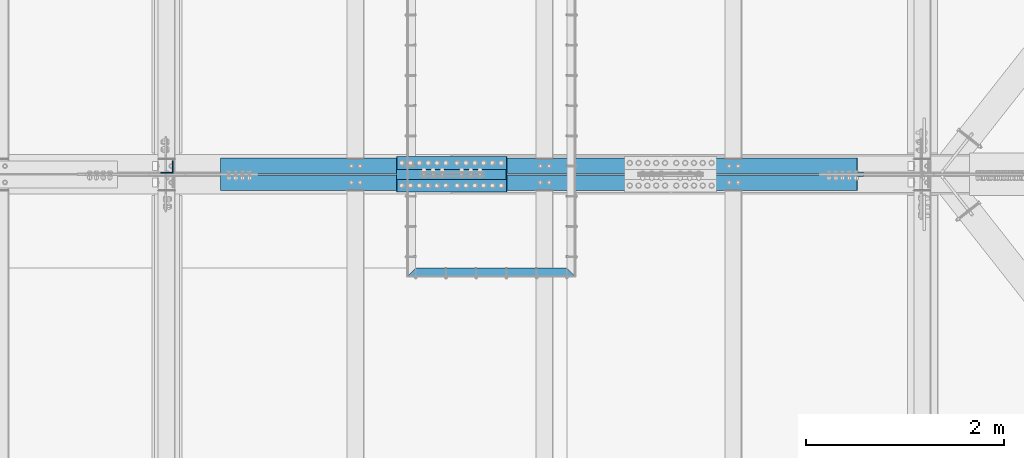
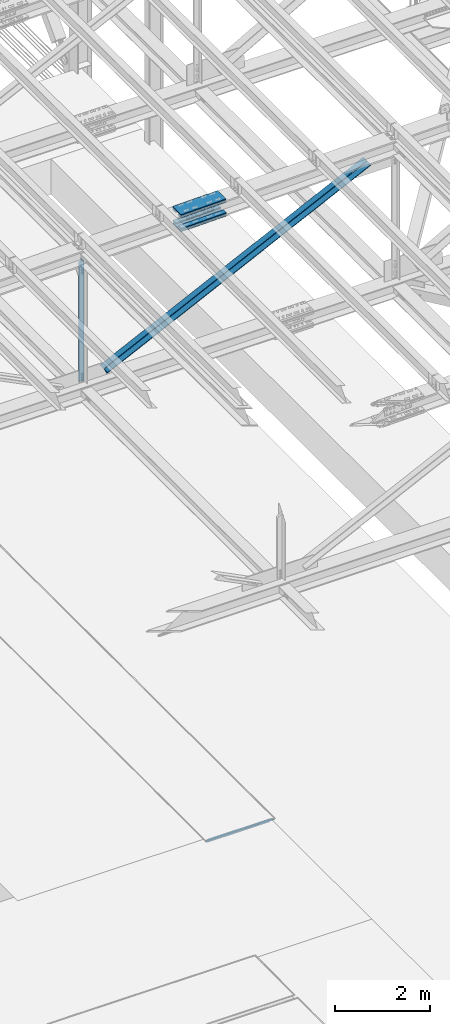
# One storey, part 1898 of 3843: 8 beams, 2 members, 5 elements without a shape of their own.
"""IFC2X3 building model written with IfcOpenShell, lengths in millimetres."""

from ifc_helpers import new_model, si_unit, frame, origin_with_axes, place, context, subcontext, project, spatial, faceted_brep, material, type_object, element, aggregate, save


model = new_model("IFC2X3")

# Units and contexts
model_context = context("Model", 3, precision=1e-05, world=origin_with_axes())
body_context = subcontext(model_context, "Body", "Model", "MODEL_VIEW")
ifc_project = project(units=[si_unit("LENGTHUNIT", "METRE", prefix="MILLI"), si_unit("AREAUNIT", "SQUARE_METRE"), si_unit("VOLUMEUNIT", "CUBIC_METRE"), si_unit("MASSUNIT", "GRAM", prefix="KILO"), si_unit("TIMEUNIT", "SECOND"), si_unit("PLANEANGLEUNIT", "RADIAN"), si_unit("SOLIDANGLEUNIT", "STERADIAN"), si_unit("THERMODYNAMICTEMPERATUREUNIT", "DEGREE_CELSIUS"), si_unit("LUMINOUSINTENSITYUNIT", "LUMEN")], contexts=[model_context])

# Site, building, storey
site_placement = place(None, origin_with_axes())
site = spatial("IfcSite", under=ifc_project, at=site_placement, CompositionType="ELEMENT")
building_placement = place(site_placement, origin_with_axes())
building = spatial("IfcBuilding", under=site, at=building_placement, Name="Undefined", CompositionType="ELEMENT")
storey_placement = place(building_placement, origin_with_axes())
storey = spatial("IfcBuildingStorey", under=building, at=storey_placement, Name="Undefined", CompositionType="ELEMENT", Elevation=0.0)

# Assembly, beam
assembly_1_placement = place(storey_placement, origin_with_axes())
assembly_1 = element("IfcElementAssembly", 1, at=assembly_1_placement, inside=storey, Name="EMBED_ANGLE", AssemblyPlace="NOTDEFINED", PredefinedType="RIGID_FRAME")
ifc_material_1 = material(Name="STEEL/A36")
beam_type_1 = type_object("IfcBeamType", Name="L3-1/2X3-1/2X5/16", PredefinedType="NOTDEFINED")
beam_1_placement = place(assembly_1_placement, frame((65056.5755550862, 66281.427, 30410.15), z_axis=(0.0, -1.0, 0.0), x_axis=(1.0, 0.0, 0.0)))
beam_1 = element("IfcBeam", 2, at=beam_1_placement, type_object=beam_type_1, material=ifc_material_1, Name="EMBED_ANGLE", ObjectType="L3-1/2X3-1/2X5/16", context=body_context, shape_type="Brep", body=[
    faceted_brep([(88.8999999971129, 44.4500000000007, -44.4499999999971), (-3.63797880709171e-12, 44.4499999999971, 44.4500000000007), (1701.73642350091, 44.4500000000007, 44.4499999912659), (1612.83642269864, 44.4500000000007, -44.4500000082771), (-3.63797880709171e-12, 36.5124999999971, 44.4500000000007), (1701.73642350091, 36.5125000000007, 44.4499999912659), (80.9624999971129, 36.5125000000007, -36.5124999999971), (1620.77392277028, 36.5125000000007, -36.5125000083208), (80.9624999971129, -44.4500000000007, -36.5124999999971), (1620.77392277028, -44.4500000000007, -36.5125000083208), (88.8999999971129, -44.4500000000007, -44.4499999999971), (1612.83642269864, -44.4500000000007, -44.4500000082771)], [[[0, 1, 2, 3]], [[1, 4, 5, 2]], [[4, 6, 7, 5]], [[6, 8, 9, 7]], [[8, 10, 11, 9]], [[10, 0, 3, 11]], [[5, 7, 9, 11, 3, 2]], [[10, 8, 6, 4, 1, 0]]]),
])
aggregate(assembly_1, [beam_1])

# Assembly, beams
assembly_2_placement = place(storey_placement, origin_with_axes())
assembly_2 = element("IfcElementAssembly", 3, at=assembly_2_placement, inside=storey, Name="BEAM", AssemblyPlace="NOTDEFINED", PredefinedType="RIGID_FRAME")
ifc_material_2 = material(Name="STEEL/A572-50")
beam_type_2 = type_object("IfcBeamType", PredefinedType="NOTDEFINED")
beam_2_placement = place(assembly_2_placement, frame((64955.3533419388, 67386.2, 46066.1154758346), z_axis=(0.0, -1.0, 0.0), x_axis=(0.999763513448012, 0.0, 0.0217466590097504)))
beam_2 = element("IfcBeam", 4, at=beam_2_placement, type_object=beam_type_2, material=ifc_material_2, Name="PLATE", context=body_context, shape_type="Brep", body=[
    faceted_brep([(-4.36557456851006e-11, 12.7000000000116, -63.5), (-4.36557456851006e-11, 12.7000000000116, 63.5), (1104.90000001677, 12.7000000017251, 63.5), (1104.90000001677, 12.7000000017251, -63.5), (1.45519152283669e-11, -12.700000000008, 63.5), (1104.90000001682, -12.6999999982909, 63.5), (1.45519152283669e-11, -12.700000000008, -63.5), (1104.90000001682, -12.6999999982909, -63.5)], [[[0, 1, 2, 3]], [[1, 4, 5, 2]], [[4, 6, 7, 5]], [[6, 0, 3, 7]], [[5, 7, 3, 2]], [[6, 4, 1, 0]]]),
])
beam_3_placement = place(assembly_2_placement, frame((64961.7738685423, 67386.2, 45770.943315952), z_axis=(0.0, -1.0, 0.0), x_axis=(0.999763513448012, 0.0, 0.0217466590097504)))
beam_3 = element("IfcBeam", 5, at=beam_3_placement, type_object=beam_type_2, material=ifc_material_2, Name="PLATE", context=body_context, shape_type="Brep", body=[
    faceted_brep([(-4.36557456851006e-11, 12.7000000000116, -63.5), (-4.36557456851006e-11, 12.7000000000116, 63.5), (1104.90000001677, 12.7000000017251, 63.5), (1104.90000001677, 12.7000000017251, -63.5), (1.45519152283669e-11, -12.700000000008, 63.5), (1104.90000001682, -12.6999999982909, 63.5), (1.45519152283669e-11, -12.700000000008, -63.5), (1104.90000001682, -12.6999999982909, -63.5)], [[[0, 1, 2, 3]], [[1, 4, 5, 2]], [[4, 6, 7, 5]], [[6, 0, 3, 7]], [[5, 7, 3, 2]], [[6, 4, 1, 0]]]),
])
beam_4_placement = place(assembly_2_placement, frame((64955.3533419388, 67157.6, 46066.1154758346), z_axis=(0.0, -1.0, 0.0), x_axis=(0.999763513448012, 0.0, 0.0217466590097504)))
beam_4 = element("IfcBeam", 6, at=beam_4_placement, type_object=beam_type_2, material=ifc_material_2, Name="PLATE", context=body_context, shape_type="Brep", body=[
    faceted_brep([(-4.36557456851006e-11, 12.7000000000116, -63.5), (-4.36557456851006e-11, 12.7000000000116, 63.5), (1104.90000001677, 12.7000000017251, 63.5), (1104.90000001677, 12.7000000017251, -63.5), (1.45519152283669e-11, -12.700000000008, 63.5), (1104.90000001682, -12.6999999982909, 63.5), (1.45519152283669e-11, -12.700000000008, -63.5), (1104.90000001682, -12.6999999982909, -63.5)], [[[0, 1, 2, 3]], [[1, 4, 5, 2]], [[4, 6, 7, 5]], [[6, 0, 3, 7]], [[5, 7, 3, 2]], [[6, 4, 1, 0]]]),
])
beam_5_placement = place(assembly_2_placement, frame((64961.7738685423, 67157.6, 45770.943315952), z_axis=(0.0, -1.0, 0.0), x_axis=(0.999763513448012, 0.0, 0.0217466590097504)))
beam_5 = element("IfcBeam", 7, at=beam_5_placement, type_object=beam_type_2, material=ifc_material_2, Name="PLATE", context=body_context, shape_type="Brep", body=[
    faceted_brep([(-4.36557456851006e-11, 12.7000000000116, -63.5), (-4.36557456851006e-11, 12.7000000000116, 63.5), (1104.90000001677, 12.7000000017251, 63.5), (1104.90000001677, 12.7000000017251, -63.5), (1.45519152283669e-11, -12.700000000008, 63.5), (1104.90000001682, -12.6999999982909, 63.5), (1.45519152283669e-11, -12.700000000008, -63.5), (1104.90000001682, -12.6999999982909, -63.5)], [[[0, 1, 2, 3]], [[1, 4, 5, 2]], [[4, 6, 7, 5]], [[6, 0, 3, 7]], [[5, 7, 3, 2]], [[6, 4, 1, 0]]]),
])
beam_type_3 = type_object("IfcBeamType", PredefinedType="NOTDEFINED")
beam_6_placement = place(assembly_2_placement, frame((66058.6433708247, 67271.9, 46152.1463653092), z_axis=(0.0, -1.0, 0.0), x_axis=(-0.999763513448012, 0.0, -0.0217466590097481)))
beam_6 = element("IfcBeam", 8, at=beam_6_placement, type_object=beam_type_3, material=ifc_material_2, Name="PLATE", context=body_context, shape_type="Brep", body=[
    faceted_brep([(-1.45519152283669e-11, 12.7000000000025, -177.800000000003), (-1.45519152283669e-11, 12.7000000000025, 177.800000000003), (1104.90000001682, 12.7000000017051, 177.800000000003), (1104.90000001682, 12.7000000017051, -177.800000000003), (4.36557456851006e-11, -12.7000000000171, 177.800000000003), (1104.90000001686, -12.6999999983072, 177.800000000003), (4.36557456851006e-11, -12.7000000000171, -177.800000000003), (1104.90000001686, -12.6999999983072, -177.800000000003)], [[[0, 1, 2, 3]], [[1, 4, 5, 2]], [[4, 6, 7, 5]], [[6, 0, 3, 7]], [[5, 7, 3, 2]], [[6, 4, 1, 0]]]),
])
beam_7_placement = place(assembly_2_placement, frame((66067.7669211937, 67271.9, 45733.0404851893), z_axis=(0.0, -1.0, 0.0), x_axis=(-0.999763513448012, 0.0, -0.0217466590097481)))
beam_7 = element("IfcBeam", 9, at=beam_7_placement, type_object=beam_type_3, material=ifc_material_2, Name="PLATE", context=body_context, shape_type="Brep", body=[
    faceted_brep([(-1.45519152283669e-11, 12.7000000000025, -177.800000000003), (-1.45519152283669e-11, 12.7000000000025, 177.800000000003), (1104.90000001682, 12.7000000017051, 177.800000000003), (1104.90000001682, 12.7000000017051, -177.800000000003), (4.36557456851006e-11, -12.7000000000171, 177.800000000003), (1104.90000001686, -12.6999999983072, 177.800000000003), (4.36557456851006e-11, -12.7000000000171, -177.800000000003), (1104.90000001686, -12.6999999983072, -177.800000000003)], [[[0, 1, 2, 3]], [[1, 4, 5, 2]], [[4, 6, 7, 5]], [[6, 0, 3, 7]], [[5, 7, 3, 2]], [[6, 4, 1, 0]]]),
])
aggregate(assembly_2, [beam_2, beam_3, beam_4, beam_5, beam_6, beam_7])

# Assembly, beam
assembly_3_placement = place(storey_placement, origin_with_axes())
assembly_3 = element("IfcElementAssembly", 10, at=assembly_3_placement, inside=storey, Name="ANGLE", AssemblyPlace="NOTDEFINED", PredefinedType="RIGID_FRAME")
beam_type_4 = type_object("IfcBeamType", Name="L5X5X3/8", PredefinedType="NOTDEFINED")
beam_8_placement = place(assembly_3_placement, frame((62636.4, 67344.925, 45867.3102138848), z_axis=(-1.0, 0.0, 0.0), x_axis=(0.0, 0.0, -1.0)))
beam_8 = element("IfcBeam", 11, at=beam_8_placement, type_object=beam_type_4, material=ifc_material_2, Name="ANGLE", ObjectType="L5X5X3/8", context=body_context, shape_type="Brep", body=[
    faceted_brep([(224.213250600216, 63.5, -63.5000000007203), (224.213250600224, 63.5, 63.4999999992797), (3316.70145277902, 63.5, 63.4999999893989), (3316.70145277901, 63.5, -63.5000000106011), (224.213250600224, 53.9750000000058, 63.4999999992797), (3316.70145277902, 53.9750000000058, 63.4999999893989), (224.213250600224, 53.9750000000058, -53.9750000007189), (3316.70145277902, 53.9750000000058, -53.9750000105996), (224.213250600224, -63.5, -53.9750000007189), (3316.70145277902, -63.5, -53.9750000105996), (224.213250600216, -63.5, -63.5000000007203), (3316.70145277901, -63.5, -63.5000000106011)], [[[0, 1, 2, 3]], [[1, 4, 5, 2]], [[4, 6, 7, 5]], [[6, 8, 9, 7]], [[8, 10, 11, 9]], [[10, 0, 3, 11]], [[5, 7, 9, 11, 3, 2]], [[10, 8, 6, 4, 1, 0]]]),
])
aggregate(assembly_3, [beam_8])

# Assembly, member
assembly_4_placement = place(storey_placement, origin_with_axes())
assembly_4 = element("IfcElementAssembly", 12, at=assembly_4_placement, inside=storey, Name="ANGLE", AssemblyPlace="NOTDEFINED", PredefinedType="RIGID_FRAME")
member_type = type_object("IfcMemberType", Name="L6X6X1/2", PredefinedType="NOTDEFINED")
member_1_placement = place(assembly_4_placement, frame((70256.4, 67357.625, 46031.6211476753), z_axis=(0.0, 1.0, 0.0), x_axis=(-0.899996515545136, 0.0, -0.435897088779696)))
member_1 = element("IfcMember", 13, at=member_1_placement, type_object=member_type, material=ifc_material_2, Name="ANGLE", ObjectType="L6X6X1/2", context=body_context, shape_type="Brep", body=[
    faceted_brep([(699.710310957555, 76.1999999997279, -76.1999999999971), (699.710310957555, 76.1999999997279, 76.1999999999971), (7828.87434037951, 76.1999999952022, 76.1999999999971), (7828.87434037951, 76.1999999952022, -76.1999999999971), (699.710310957526, 63.499999999709, 76.1999999999971), (7828.87434037945, 63.4999999951688, 76.1999999999971), (699.710310957526, 63.499999999709, -63.5), (7828.87434037945, 63.4999999951688, -63.5), (699.710310957045, -76.200000000601, -63.5), (7828.87434037898, -76.2000000051339, -63.5), (699.710310957045, -76.200000000601, -76.1999999999971), (7828.87434037898, -76.2000000051339, -76.1999999999971)], [[[0, 1, 2, 3]], [[1, 4, 5, 2]], [[4, 6, 7, 5]], [[6, 8, 9, 7]], [[8, 10, 11, 9]], [[10, 0, 3, 11]], [[5, 7, 9, 11, 3, 2]], [[10, 8, 6, 4, 1, 0]]]),
])
aggregate(assembly_4, [member_1])

assembly_5_placement = place(storey_placement, origin_with_axes())
assembly_5 = element("IfcElementAssembly", 14, at=assembly_5_placement, inside=storey, Name="ANGLE", AssemblyPlace="NOTDEFINED", PredefinedType="RIGID_FRAME")
member_2_placement = place(assembly_5_placement, frame((62636.4, 67186.175, 42341.0115089512), z_axis=(0.0, -1.0, 0.0), x_axis=(0.899996515545135, 0.0, 0.435897088779698)))
member_2 = element("IfcMember", 15, at=member_2_placement, type_object=member_type, material=ifc_material_2, Name="ANGLE", ObjectType="L6X6X1/2", context=body_context, shape_type="Brep", body=[
    faceted_brep([(637.825105297554, 76.1999999983109, -76.1999999999971), (637.825105297554, 76.1999999983109, 76.1999999999971), (7766.98913481286, 76.1999999802301, 76.1999999999971), (7766.98913481286, 76.1999999802301, -76.1999999999971), (637.825105297568, 63.499999998332, 76.1999999999971), (7766.98913481286, 63.499999980244, 76.1999999999971), (637.825105297568, 63.499999998332, -63.5), (7766.98913481286, 63.499999980244, -63.5), (637.825105297568, -76.2000000015414, -63.5), (7766.98913481286, -76.2000000196185, -63.5), (637.825105297568, -76.2000000015414, -76.1999999999971), (7766.98913481286, -76.2000000196185, -76.1999999999971)], [[[0, 1, 2, 3]], [[1, 4, 5, 2]], [[4, 6, 7, 5]], [[6, 8, 9, 7]], [[8, 10, 11, 9]], [[10, 0, 3, 11]], [[5, 7, 9, 11, 3, 2]], [[10, 8, 6, 4, 1, 0]]]),
])
aggregate(assembly_5, [member_2])

save(model, "model.ifc")
